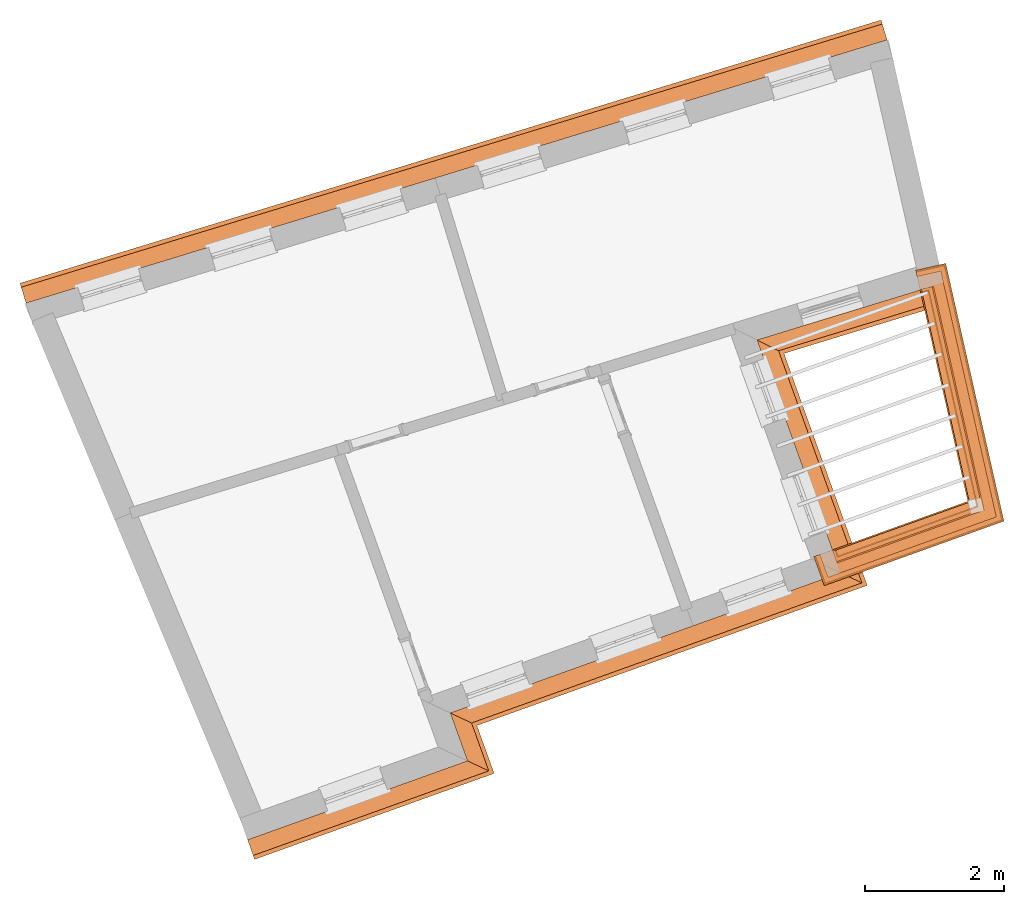
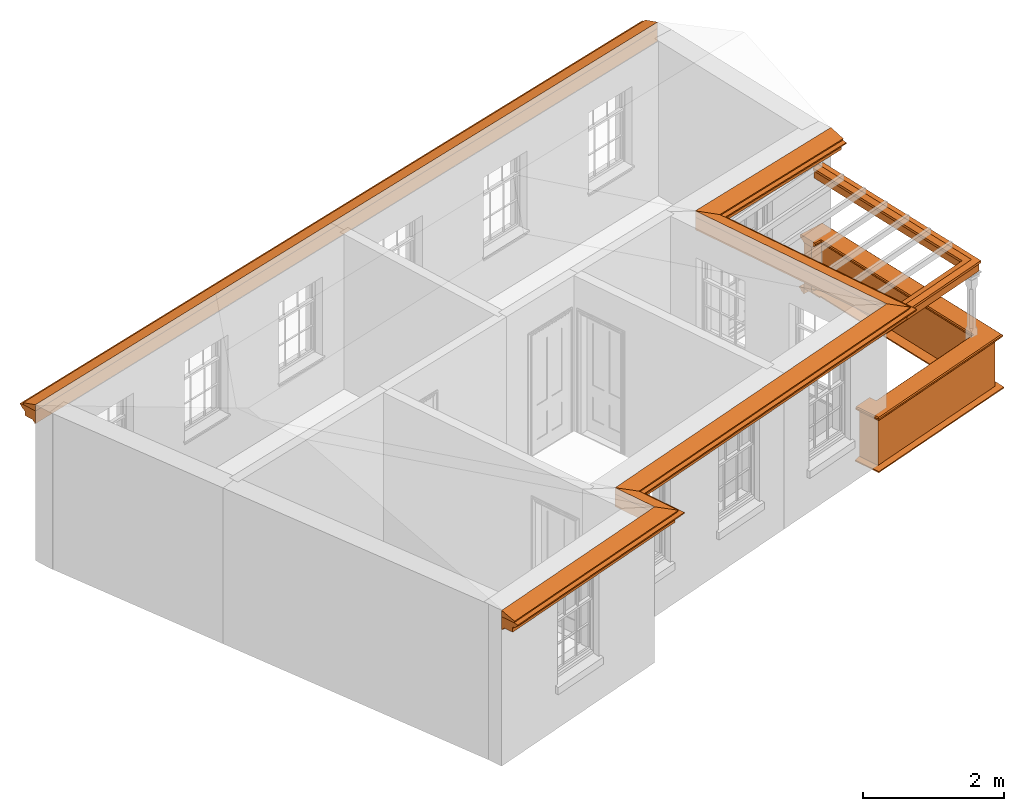
# One storey, part 9 of 10: 9 proxies.
"""IFC2X3 building model written with IfcOpenShell, lengths in metres."""

from ifc_helpers import new_model, entity, si_unit, frame, origin, place, context, subcontext, project, spatial, element, save


model = new_model("IFC2X3")

# Units and contexts
model_context = context("Model", 3, world=origin())
body_context = subcontext(model_context, "Body", "Model", "MODEL_VIEW")
ifc_project = project(units=[si_unit("PLANEANGLEUNIT", "RADIAN"), si_unit("MASSUNIT", "GRAM", prefix="KILO"), si_unit("FORCEUNIT", "NEWTON", prefix="KILO"), si_unit("LENGTHUNIT", "METRE")], contexts=[model_context])

# Site, building, storey
site_placement = place(None, origin())
site = spatial("IfcSite", under=ifc_project, at=site_placement, CompositionType="ELEMENT")
building_placement = place(None, origin())
building = spatial("IfcBuilding", under=site, at=building_placement, Name="Building plot-9", CompositionType="ELEMENT")
storey_placement = place(None, frame((0.0, 0.0, 4.3)))
storey = spatial("IfcBuildingStorey", under=building, at=storey_placement, Name="Floor 1", CompositionType="ELEMENT", Elevation=4.3)

# Proxies
proxy_1_placement = place(storey_placement, frame((0.0, 0.0, 2.7)))
axis2_placement3_d_1 = entity("IfcAxis2Placement3D", entity("IfcCartesianPoint", [0.0, 0.0, 0.0]))
element("IfcBuildingElementProxy", 1, at=proxy_1_placement, inside=storey, Name="eaves", CompositionType="ELEMENT", context=body_context, shape_type="SweptSolid", held_by="IfcProductRepresentation", body=[
    entity("IfcSurfaceCurveSweptAreaSolid", entity("IfcArbitraryClosedProfileDef", "AREA", None, entity("IfcPolyline", [entity("IfcCartesianPoint", [-0.11, 0.25]), entity("IfcCartesianPoint", [-0.33, 0.25]), entity("IfcCartesianPoint", [-0.33, 0.265]), entity("IfcCartesianPoint", [-0.318, 0.268]), entity("IfcCartesianPoint", [-0.309, 0.274]), entity("IfcCartesianPoint", [-0.303, 0.283]), entity("IfcCartesianPoint", [-0.3, 0.295]), entity("IfcCartesianPoint", [-0.285, 0.295]), entity("IfcCartesianPoint", [-0.285, 0.455]), entity("IfcCartesianPoint", [-0.205, 0.455]), entity("IfcCartesianPoint", [-0.205, 0.47]), entity("IfcCartesianPoint", [-0.19, 0.47]), entity("IfcCartesianPoint", [-0.189, 0.483]), entity("IfcCartesianPoint", [-0.186, 0.494]), entity("IfcCartesianPoint", [-0.179, 0.506]), entity("IfcCartesianPoint", [-0.17, 0.514]), entity("IfcCartesianPoint", [-0.16, 0.52]), entity("IfcCartesianPoint", [-0.149, 0.529]), entity("IfcCartesianPoint", [-0.143, 0.539]), entity("IfcCartesianPoint", [-0.14, 0.55]), entity("IfcCartesianPoint", [-0.12, 0.55]), entity("IfcCartesianPoint", [-0.11, 0.48]), entity("IfcCartesianPoint", [-0.11, 0.25])])), axis2_placement3_d_1, entity("IfcPolyline", [entity("IfcCartesianPoint", [40.5484472889686, 23.792961608081]), entity("IfcCartesianPoint", [28.1638571649136, 20.0069103240994])]), 0.0, 1.0, entity("IfcPlane", axis2_placement3_d_1)),
])
proxy_2_placement = place(storey_placement, frame((0.0, 0.0, 2.7)))
axis2_placement3_d_2 = entity("IfcAxis2Placement3D", entity("IfcCartesianPoint", [0.0, 0.0, 0.0]))
element("IfcBuildingElementProxy", 2, at=proxy_2_placement, inside=storey, Name="eaves", CompositionType="ELEMENT", context=body_context, shape_type="SweptSolid", held_by="IfcProductRepresentation", body=[
    entity("IfcSurfaceCurveSweptAreaSolid", entity("IfcArbitraryClosedProfileDef", "AREA", None, entity("IfcPolyline", [entity("IfcCartesianPoint", [-0.11, 0.25]), entity("IfcCartesianPoint", [-0.11, 0.48]), entity("IfcCartesianPoint", [-0.08, 0.49]), entity("IfcCartesianPoint", [0.0, 0.25]), entity("IfcCartesianPoint", [-0.11, 0.25])])), axis2_placement3_d_2, entity("IfcPolyline", [entity("IfcCartesianPoint", [40.5484472889686, 23.792961608081]), entity("IfcCartesianPoint", [28.1638571649136, 20.0069103240994])]), 0.0, 1.0, entity("IfcPlane", axis2_placement3_d_2)),
])
proxy_3_placement = place(storey_placement, frame((0.0, 0.0, 2.7)))
axis2_placement3_d_3 = entity("IfcAxis2Placement3D", entity("IfcCartesianPoint", [0.0, 0.0, 0.0]))
element("IfcBuildingElementProxy", 3, at=proxy_3_placement, inside=storey, Name="eaves", CompositionType="ELEMENT", context=body_context, shape_type="SweptSolid", held_by="IfcProductRepresentation", body=[
    entity("IfcSurfaceCurveSweptAreaSolid", entity("IfcArbitraryClosedProfileDef", "AREA", None, entity("IfcPolyline", [entity("IfcCartesianPoint", [-0.11, 0.25]), entity("IfcCartesianPoint", [-0.33, 0.25]), entity("IfcCartesianPoint", [-0.33, 0.265]), entity("IfcCartesianPoint", [-0.318, 0.268]), entity("IfcCartesianPoint", [-0.309, 0.274]), entity("IfcCartesianPoint", [-0.303, 0.283]), entity("IfcCartesianPoint", [-0.3, 0.295]), entity("IfcCartesianPoint", [-0.285, 0.295]), entity("IfcCartesianPoint", [-0.285, 0.455]), entity("IfcCartesianPoint", [-0.205, 0.455]), entity("IfcCartesianPoint", [-0.205, 0.47]), entity("IfcCartesianPoint", [-0.19, 0.47]), entity("IfcCartesianPoint", [-0.189, 0.483]), entity("IfcCartesianPoint", [-0.186, 0.494]), entity("IfcCartesianPoint", [-0.179, 0.506]), entity("IfcCartesianPoint", [-0.17, 0.514]), entity("IfcCartesianPoint", [-0.16, 0.52]), entity("IfcCartesianPoint", [-0.149, 0.529]), entity("IfcCartesianPoint", [-0.143, 0.539]), entity("IfcCartesianPoint", [-0.14, 0.55]), entity("IfcCartesianPoint", [-0.12, 0.55]), entity("IfcCartesianPoint", [-0.11, 0.48]), entity("IfcCartesianPoint", [-0.11, 0.25])])), axis2_placement3_d_3, entity("IfcPolyline", [entity("IfcCartesianPoint", [31.1921943234739, 12.7638113486754]), entity("IfcCartesianPoint", [34.1187222725909, 13.8143365353496]), entity("IfcCartesianPoint", [33.8713155279936, 14.5035563294568]), entity("IfcCartesianPoint", [39.4852212696492, 16.5187598333234]), entity("IfcCartesianPoint", [38.2785471357262, 19.8802837864826]), entity("IfcCartesianPoint", [41.2284636332409, 20.7820928113418])]), 0.0, 1.0, entity("IfcPlane", axis2_placement3_d_3)),
])
proxy_4_placement = place(storey_placement, frame((0.0, 0.0, 2.7)))
axis2_placement3_d_4 = entity("IfcAxis2Placement3D", entity("IfcCartesianPoint", [0.0, 0.0, 0.0]))
element("IfcBuildingElementProxy", 4, at=proxy_4_placement, inside=storey, Name="eaves", CompositionType="ELEMENT", context=body_context, shape_type="SweptSolid", held_by="IfcProductRepresentation", body=[
    entity("IfcSurfaceCurveSweptAreaSolid", entity("IfcArbitraryClosedProfileDef", "AREA", None, entity("IfcPolyline", [entity("IfcCartesianPoint", [-0.11, 0.25]), entity("IfcCartesianPoint", [-0.11, 0.48]), entity("IfcCartesianPoint", [-0.08, 0.49]), entity("IfcCartesianPoint", [0.0, 0.25]), entity("IfcCartesianPoint", [-0.11, 0.25])])), axis2_placement3_d_4, entity("IfcPolyline", [entity("IfcCartesianPoint", [31.1921943234739, 12.7638113486754]), entity("IfcCartesianPoint", [34.1187222725909, 13.8143365353496]), entity("IfcCartesianPoint", [33.8713155279936, 14.5035563294568]), entity("IfcCartesianPoint", [39.4852212696492, 16.5187598333234]), entity("IfcCartesianPoint", [38.2785471357262, 19.8802837864826]), entity("IfcCartesianPoint", [41.2284636332409, 20.7820928113418])]), 0.0, 1.0, entity("IfcPlane", axis2_placement3_d_4)),
])
proxy_5_placement = place(storey_placement, origin())
axis2_placement3_d_5 = entity("IfcAxis2Placement3D", entity("IfcCartesianPoint", [0.0, 0.0, 0.0]))
element("IfcBuildingElementProxy", 5, at=proxy_5_placement, inside=storey, Name="parapet", CompositionType="ELEMENT", context=body_context, shape_type="SweptSolid", held_by="IfcProductRepresentation", body=[
    entity("IfcSurfaceCurveSweptAreaSolid", entity("IfcArbitraryClosedProfileDef", "AREA", None, entity("IfcPolyline", [entity("IfcCartesianPoint", [0.0, 0.25]), entity("IfcCartesianPoint", [0.795, 0.25]), entity("IfcCartesianPoint", [0.795, 0.09]), entity("IfcCartesianPoint", [0.02, 0.09]), entity("IfcCartesianPoint", [0.02, -0.08]), entity("IfcCartesianPoint", [0.0, -0.08]), entity("IfcCartesianPoint", [0.0, 0.25])])), axis2_placement3_d_5, entity("IfcPolyline", [entity("IfcCartesianPoint", [39.7432065452005, 16.7176155538816]), entity("IfcCartesianPoint", [39.7769923565275, 16.623495848437]), entity("IfcCartesianPoint", [41.7519928065851, 17.332454639384]), entity("IfcCartesianPoint", [41.0576803469834, 20.4066215140629]), entity("IfcCartesianPoint", [40.9601372404586, 20.3845910267897])]), 0.0, 1.0, entity("IfcPlane", axis2_placement3_d_5)),
])
proxy_6_placement = place(storey_placement, origin())
axis2_placement3_d_6 = entity("IfcAxis2Placement3D", entity("IfcCartesianPoint", [0.0, 0.0, 0.0]))
element("IfcBuildingElementProxy", 6, at=proxy_6_placement, inside=storey, Name="parapet", CompositionType="ELEMENT", context=body_context, shape_type="SweptSolid", held_by="IfcProductRepresentation", body=[
    entity("IfcSurfaceCurveSweptAreaSolid", entity("IfcArbitraryClosedProfileDef", "AREA", None, entity("IfcPolyline", [entity("IfcCartesianPoint", [0.795, 0.265]), entity("IfcCartesianPoint", [0.807, 0.268]), entity("IfcCartesianPoint", [0.816, 0.274]), entity("IfcCartesianPoint", [0.822, 0.283]), entity("IfcCartesianPoint", [0.825, 0.295]), entity("IfcCartesianPoint", [0.84, 0.295]), entity("IfcCartesianPoint", [0.84, 0.305]), entity("IfcCartesianPoint", [0.842, 0.317]), entity("IfcCartesianPoint", [0.849, 0.326]), entity("IfcCartesianPoint", [0.858, 0.333]), entity("IfcCartesianPoint", [0.87, 0.335]), entity("IfcCartesianPoint", [0.882, 0.333]), entity("IfcCartesianPoint", [0.891, 0.326]), entity("IfcCartesianPoint", [0.898, 0.317]), entity("IfcCartesianPoint", [0.9, 0.305]), entity("IfcCartesianPoint", [0.9, 0.035]), entity("IfcCartesianPoint", [0.898, 0.023]), entity("IfcCartesianPoint", [0.891, 0.014]), entity("IfcCartesianPoint", [0.882, 0.007]), entity("IfcCartesianPoint", [0.87, 0.005]), entity("IfcCartesianPoint", [0.858, 0.007]), entity("IfcCartesianPoint", [0.849, 0.014]), entity("IfcCartesianPoint", [0.842, 0.023]), entity("IfcCartesianPoint", [0.84, 0.035]), entity("IfcCartesianPoint", [0.84, 0.045]), entity("IfcCartesianPoint", [0.825, 0.045]), entity("IfcCartesianPoint", [0.822, 0.057]), entity("IfcCartesianPoint", [0.816, 0.066]), entity("IfcCartesianPoint", [0.807, 0.072]), entity("IfcCartesianPoint", [0.795, 0.075]), entity("IfcCartesianPoint", [0.795, 0.265])])), axis2_placement3_d_6, entity("IfcPolyline", [entity("IfcCartesianPoint", [39.7432065452005, 16.7176155538816]), entity("IfcCartesianPoint", [39.7769923565275, 16.623495848437]), entity("IfcCartesianPoint", [41.7519928065851, 17.332454639384]), entity("IfcCartesianPoint", [41.0576803469834, 20.4066215140629]), entity("IfcCartesianPoint", [40.9601372404586, 20.3845910267897])]), 0.0, 1.0, entity("IfcPlane", axis2_placement3_d_6)),
])
proxy_7_placement = place(storey_placement, origin())
axis2_placement3_d_7 = entity("IfcAxis2Placement3D", entity("IfcCartesianPoint", [0.0, 0.0, 0.0]))
element("IfcBuildingElementProxy", 7, at=proxy_7_placement, inside=storey, Name="parapet", CompositionType="ELEMENT", context=body_context, shape_type="SweptSolid", held_by="IfcProductRepresentation", body=[
    entity("IfcSurfaceCurveSweptAreaSolid", entity("IfcArbitraryClosedProfileDef", "AREA", None, entity("IfcPolyline", [entity("IfcCartesianPoint", [-0.1, 0.25]), entity("IfcCartesianPoint", [-0.1, 0.265]), entity("IfcCartesianPoint", [-0.085, 0.265]), entity("IfcCartesianPoint", [-0.084, 0.278]), entity("IfcCartesianPoint", [-0.081, 0.289]), entity("IfcCartesianPoint", [-0.074, 0.301]), entity("IfcCartesianPoint", [-0.065, 0.309]), entity("IfcCartesianPoint", [-0.055, 0.315]), entity("IfcCartesianPoint", [-0.044, 0.324]), entity("IfcCartesianPoint", [-0.038, 0.334]), entity("IfcCartesianPoint", [-0.035, 0.345]), entity("IfcCartesianPoint", [-0.015, 0.345]), entity("IfcCartesianPoint", [0.0, 0.25]), entity("IfcCartesianPoint", [-0.1, 0.25])])), axis2_placement3_d_7, entity("IfcPolyline", [entity("IfcCartesianPoint", [39.7432065452005, 16.7176155538816]), entity("IfcCartesianPoint", [39.7769923565275, 16.623495848437]), entity("IfcCartesianPoint", [41.7519928065851, 17.332454639384]), entity("IfcCartesianPoint", [41.0576803469834, 20.4066215140629]), entity("IfcCartesianPoint", [40.9601372404586, 20.3845910267897])]), 0.0, 1.0, entity("IfcPlane", axis2_placement3_d_7)),
])
proxy_8_placement = place(storey_placement, frame((0.0, 0.0, 2.7)))
axis2_placement3_d_8 = entity("IfcAxis2Placement3D", entity("IfcCartesianPoint", [0.0, 0.0, 0.0]))
element("IfcBuildingElementProxy", 8, at=proxy_8_placement, inside=storey, Name="pergola beam", CompositionType="ELEMENT", context=body_context, shape_type="SweptSolid", held_by="IfcProductRepresentation", body=[
    entity("IfcSurfaceCurveSweptAreaSolid", entity("IfcArbitraryClosedProfileDef", "AREA", None, entity("IfcPolyline", [entity("IfcCartesianPoint", [-0.7, -0.08]), entity("IfcCartesianPoint", [-0.7, 0.08]), entity("IfcCartesianPoint", [-0.56, 0.08]), entity("IfcCartesianPoint", [-0.56, -0.08]), entity("IfcCartesianPoint", [-0.7, -0.08])])), axis2_placement3_d_8, entity("IfcPolyline", [entity("IfcCartesianPoint", [39.7205205332607, 16.6032243616408]), entity("IfcCartesianPoint", [41.7519928065851, 17.332454639384]), entity("IfcCartesianPoint", [41.0444620546195, 20.4651473779778])]), 0.0, 1.0, entity("IfcPlane", axis2_placement3_d_8)),
])
proxy_9_placement = place(storey_placement, frame((0.0, 0.0, 2.7)))
axis2_placement3_d_9 = entity("IfcAxis2Placement3D", entity("IfcCartesianPoint", [0.0, 0.0, 0.0]))
element("IfcBuildingElementProxy", 9, at=proxy_9_placement, inside=storey, Name="pergola beam", CompositionType="ELEMENT", context=body_context, shape_type="SweptSolid", held_by="IfcProductRepresentation", body=[
    entity("IfcSurfaceCurveSweptAreaSolid", entity("IfcArbitraryClosedProfileDef", "AREA", None, entity("IfcPolyline", [entity("IfcCartesianPoint", [-0.5, 0.0]), entity("IfcCartesianPoint", [-0.52, -0.1]), entity("IfcCartesianPoint", [-0.56, -0.1]), entity("IfcCartesianPoint", [-0.56, 0.1]), entity("IfcCartesianPoint", [-0.52, 0.1]), entity("IfcCartesianPoint", [-0.5, 0.0])])), axis2_placement3_d_9, entity("IfcPolyline", [entity("IfcCartesianPoint", [39.7205205332607, 16.6032243616408]), entity("IfcCartesianPoint", [41.7519928065851, 17.332454639384]), entity("IfcCartesianPoint", [41.0444620546195, 20.4651473779778])]), 0.0, 1.0, entity("IfcPlane", axis2_placement3_d_9)),
])

save(model, "model.ifc")
